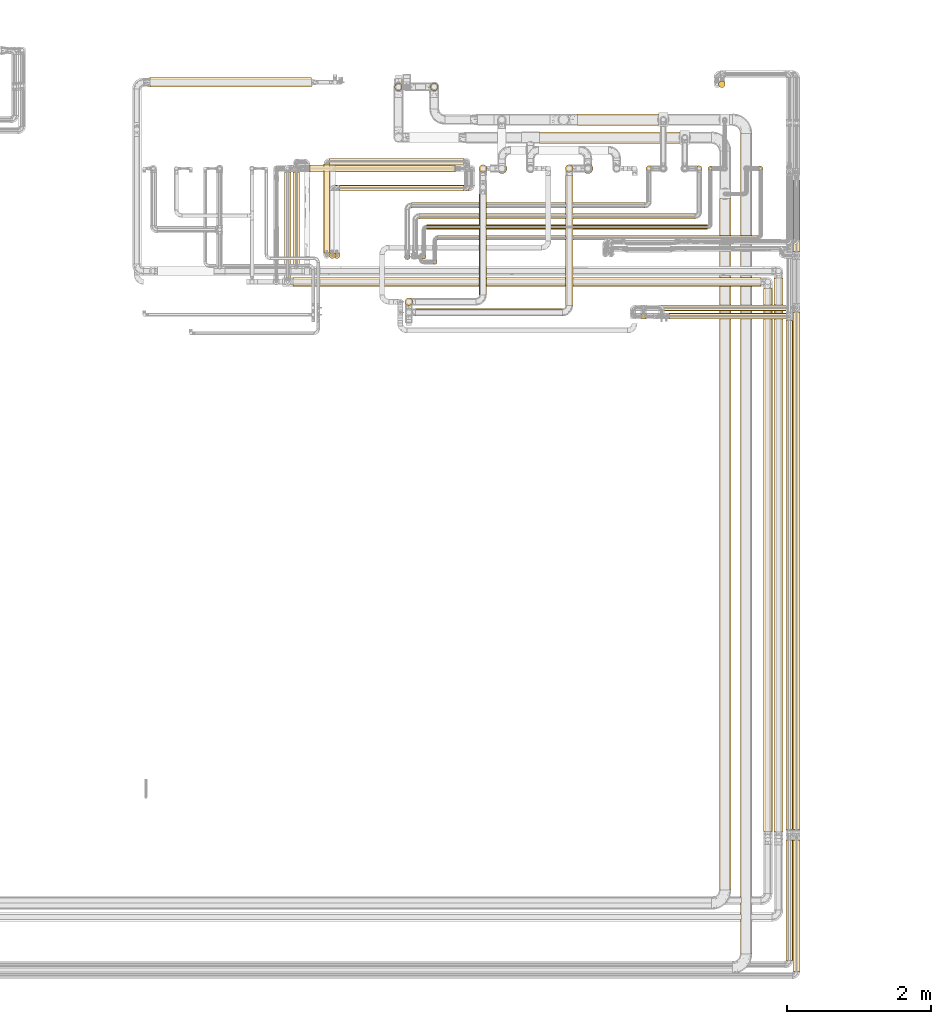
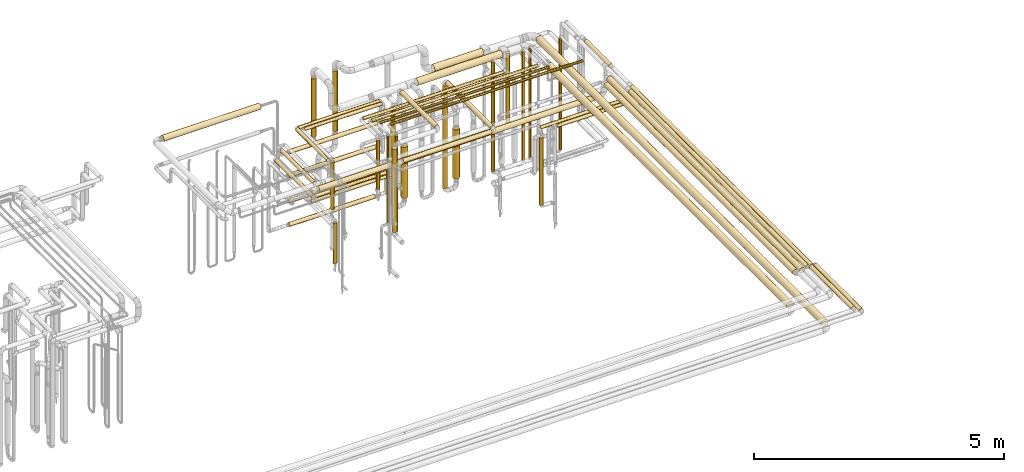
# One storey, part 8 of 827: 51 coverings.
"""IFC2X3 building model written with IfcOpenShell, lengths in millimetres."""

from ifc_helpers import new_model, entity, si_unit, converted_unit, derived_unit, direction, frame, origin, origin_2d_with_axis, place, context, subcontext, project, spatial, circle, extrude, element, save


model = new_model("IFC2X3")

# Units and contexts
model_context = context("Model", 3, precision=0.01, world=origin(), true_north=direction((6.12303176911189e-17, 1.0)))
body_context = subcontext(model_context, "Body", "Model", "MODEL_VIEW")
ifc_project = project(units=[si_unit("LENGTHUNIT", "METRE", prefix="MILLI"), si_unit("AREAUNIT", "SQUARE_METRE"), si_unit("VOLUMEUNIT", "CUBIC_METRE"), converted_unit("PLANEANGLEUNIT", "DEGREE", entity("IfcRatioMeasure", 0.0174532925199433), si_unit("PLANEANGLEUNIT", "RADIAN"), dimensions=[0, 0, 0, 0, 0, 0, 0]), si_unit("MASSUNIT", "GRAM", prefix="KILO"), derived_unit("MASSDENSITYUNIT", [(si_unit("MASSUNIT", "GRAM", prefix="KILO"), 1), (si_unit("LENGTHUNIT", "METRE"), -3)]), derived_unit("MOMENTOFINERTIAUNIT", [(si_unit("LENGTHUNIT", "METRE"), 4)]), si_unit("TIMEUNIT", "SECOND"), si_unit("FREQUENCYUNIT", "HERTZ"), si_unit("THERMODYNAMICTEMPERATUREUNIT", "DEGREE_CELSIUS"), derived_unit("THERMALTRANSMITTANCEUNIT", [(si_unit("MASSUNIT", "GRAM", prefix="KILO"), 1), (si_unit("THERMODYNAMICTEMPERATUREUNIT", "KELVIN"), -1), (si_unit("TIMEUNIT", "SECOND"), -3)]), derived_unit("VOLUMETRICFLOWRATEUNIT", [(si_unit("LENGTHUNIT", "METRE"), 3), (si_unit("TIMEUNIT", "SECOND"), -1)]), derived_unit("MASSFLOWRATEUNIT", [(si_unit("MASSUNIT", "GRAM", prefix="KILO"), 1), (si_unit("TIMEUNIT", "SECOND"), -1)]), derived_unit("ROTATIONALFREQUENCYUNIT", [(si_unit("TIMEUNIT", "SECOND"), -1)]), si_unit("ELECTRICCURRENTUNIT", "AMPERE"), si_unit("ELECTRICVOLTAGEUNIT", "VOLT"), si_unit("POWERUNIT", "WATT"), si_unit("FORCEUNIT", "NEWTON", prefix="KILO"), si_unit("ILLUMINANCEUNIT", "LUX"), si_unit("LUMINOUSFLUXUNIT", "LUMEN"), si_unit("LUMINOUSINTENSITYUNIT", "CANDELA"), derived_unit("USERDEFINED", [(si_unit("MASSUNIT", "GRAM", prefix="KILO"), -1), (si_unit("LENGTHUNIT", "METRE"), -2), (si_unit("TIMEUNIT", "SECOND"), 3), (si_unit("LUMINOUSFLUXUNIT", "LUMEN"), 1)]), derived_unit("LINEARVELOCITYUNIT", [(si_unit("LENGTHUNIT", "METRE"), 1), (si_unit("TIMEUNIT", "SECOND"), -1)]), si_unit("PRESSUREUNIT", "PASCAL"), derived_unit("USERDEFINED", [(si_unit("LENGTHUNIT", "METRE"), -2), (si_unit("MASSUNIT", "GRAM", prefix="KILO"), 1), (si_unit("TIMEUNIT", "SECOND"), -2)]), derived_unit("LINEARFORCEUNIT", [(si_unit("MASSUNIT", "GRAM", prefix="KILO"), 1), (si_unit("LENGTHUNIT", "METRE"), 1), (si_unit("TIMEUNIT", "SECOND"), -2), (si_unit("LENGTHUNIT", "METRE"), -1)]), derived_unit("PLANARFORCEUNIT", [(si_unit("MASSUNIT", "GRAM", prefix="KILO"), 1), (si_unit("LENGTHUNIT", "METRE"), 1), (si_unit("TIMEUNIT", "SECOND"), -2), (si_unit("LENGTHUNIT", "METRE"), -2)])], contexts=[model_context])

# Site, building, storey
site_placement = place(None, origin())
site = spatial("IfcSite", under=ifc_project, at=site_placement, CompositionType="ELEMENT")
building_placement = place(site_placement, origin())
building = spatial("IfcBuilding", under=site, at=building_placement, CompositionType="ELEMENT")
storey_placement = place(building_placement, frame((0.0, 0.0, 28200.0)))
storey = spatial("IfcBuildingStorey", under=building, at=storey_placement, Name="08", CompositionType="ELEMENT", Elevation=28200.0)

# Coverings
covering_1_placement = place(storey_placement, frame((60838.76, 8260.54, 2935.65)))
element("IfcCovering", 1, at=covering_1_placement, inside=storey, Name=":ADSK_", ObjectType=":ADSK_", PredefinedType="INSULATION", context=body_context, shape_type="SweptSolid", body=[
    extrude(circle(Radius=62.75, at=origin_2d_with_axis()), frame((64.35, 0.0, 64.35), z_axis=(0.0, 1.0, 0.0), x_axis=(1.0, 0.0, 0.0)), (0.0, 0.0, 1.0), 7716.83971309857),
])
covering_2_placement = place(storey_placement, frame((60075.45, 7456.2, 2816.87)))
element("IfcCovering", 2, at=covering_2_placement, inside=storey, Name=":ADSK_", ObjectType=":ADSK_", PredefinedType="INSULATION", context=body_context, shape_type="SweptSolid", body=[
    extrude(circle(Radius=81.5, at=origin_2d_with_axis()), frame((83.1, 0.0, 83.1), z_axis=(0.0, 1.0, 0.0), x_axis=(1.0, 0.0, 0.0)), (0.0, 0.0, 1.0), 9626.5836518491),
])
covering_3_placement = place(storey_placement, frame((61002.04, 8301.25, 2949.15)))
element("IfcCovering", 3, at=covering_3_placement, inside=storey, Name=":ADSK_", ObjectType=":ADSK_", PredefinedType="INSULATION", context=body_context, shape_type="SweptSolid", body=[
    extrude(circle(Radius=49.0, at=origin_2d_with_axis()), frame((50.6, 0.0, 50.6), z_axis=(0.0, 1.0, 0.0), x_axis=(1.0, 0.0, 0.0)), (0.0, 0.0, 1.0), 7085.96306405012),
])
covering_4_placement = place(storey_placement, frame((59378.46, 15400.86, 2656.65)))
element("IfcCovering", 4, at=covering_4_placement, inside=storey, Name=":ADSK_", ObjectType=":ADSK_", PredefinedType="INSULATION", context=body_context, shape_type="SweptSolid", body=[
    extrude(circle(Radius=41.75, at=origin_2d_with_axis()), frame((0.0, 43.35, 43.35), z_axis=(1.0, 0.0, 0.0), x_axis=(0.0, -1.0, 0.0)), (0.0, 0.0, 1.0), 1636.17726238864),
])
covering_5_placement = place(storey_placement, frame((61102.04, 8300.34, 2949.15)))
element("IfcCovering", 5, at=covering_5_placement, inside=storey, Name=":ADSK_", ObjectType=":ADSK_", PredefinedType="INSULATION", context=body_context, shape_type="SweptSolid", body=[
    extrude(circle(Radius=49.0, at=origin_2d_with_axis()), frame((50.6, 0.0, 50.6), z_axis=(0.0, 1.0, 0.0), x_axis=(1.0, 0.0, 0.0)), (0.0, 0.0, 1.0), 7203.18637121827),
])
covering_6_placement = place(storey_placement, frame((61102.04, 16345.88, 2949.15)))
element("IfcCovering", 6, at=covering_6_placement, inside=storey, Name=":ADSK_", ObjectType=":ADSK_", PredefinedType="INSULATION", context=body_context, shape_type="SweptSolid", body=[
    extrude(circle(Radius=49.0, at=origin_2d_with_axis()), frame((50.6, 0.0, 50.6), z_axis=(0.0, 1.0, 0.0), x_axis=(1.0, 0.0, 0.0)), (0.0, 0.0, 1.0), 994.955864647867),
])
covering_7_placement = place(storey_placement, frame((59063.14, 15517.18, 2656.65)))
element("IfcCovering", 7, at=covering_7_placement, inside=storey, Name=":ADSK_", ObjectType=":ADSK_", PredefinedType="INSULATION", context=body_context, shape_type="SweptSolid", body=[
    extrude(circle(Radius=41.75, at=origin_2d_with_axis()), frame((0.0, 43.35, 43.35), z_axis=(1.0, 0.0, 0.0), x_axis=(0.0, 1.0, 0.0)), (0.0, 0.0, 1.0), 2051.50000000003),
])
covering_8_placement = place(storey_placement, frame((58981.79, 15400.86, 908.51)))
element("IfcCovering", 8, at=covering_8_placement, inside=storey, Name=":ADSK_", ObjectType=":ADSK_", PredefinedType="INSULATION", context=body_context, shape_type="SweptSolid", body=[
    extrude(circle(Radius=41.75, at=origin_2d_with_axis()), frame((43.35, 43.35, 0.0)), (0.0, 0.0, 1.0), 1653.487023342),
])
covering_9_placement = place(storey_placement, frame((57571.89, 17847.0, 2816.87)))
element("IfcCovering", 9, at=covering_9_placement, inside=storey, Name=":ADSK_", ObjectType=":ADSK_", PredefinedType="INSULATION", context=body_context, shape_type="SweptSolid", body=[
    extrude(circle(Radius=81.5, at=origin_2d_with_axis()), frame((0.0, 83.1, 83.1), z_axis=(1.0, 0.0, 0.0), x_axis=(0.0, -1.0, 0.0)), (0.0, 0.0, 1.0), 1959.7835585026),
])
covering_10_placement = place(storey_placement, frame((55556.45, 18581.39, 1843.17)))
element("IfcCovering", 10, at=covering_10_placement, inside=storey, Name=":ADSK_", ObjectType=":ADSK_", PredefinedType="INSULATION", context=body_context, shape_type="SweptSolid", body=[
    extrude(circle(Radius=53.0, at=origin_2d_with_axis()), frame((54.6, 54.6, 0.0)), (0.0, 0.0, 1.0), 1426.57392214822),
])
covering_11_placement = place(storey_placement, frame((60065.43, 18623.72, 517.5)))
element("IfcCovering", 11, at=covering_11_placement, inside=storey, Name=":ADSK_", ObjectType=":ADSK_", PredefinedType="INSULATION", context=body_context, shape_type="SweptSolid", body=[
    extrude(circle(Radius=46.15, at=origin_2d_with_axis()), frame((47.75, 47.75, 0.0), z_axis=(0.0, 0.0, 1.0), x_axis=(0.0, -1.0, 0.0)), (0.0, 0.0, 1.0), 1769.24318880564),
])
covering_12_placement = place(storey_placement, frame((54730.19, 17456.65, 2956.65)))
element("IfcCovering", 12, at=covering_12_placement, inside=storey, Name=":ADSK_", ObjectType=":ADSK_", PredefinedType="INSULATION", context=body_context, shape_type="SweptSolid", body=[
    extrude(circle(Radius=41.75, at=origin_2d_with_axis()), frame((0.0, 43.35, 43.35), z_axis=(1.0, 0.0, 0.0), x_axis=(0.0, 1.0, 0.0)), (0.0, 0.0, 1.0), 1795.03888037783),
])
covering_13_placement = place(storey_placement, frame((54648.84, 16245.22, 1817.59)))
element("IfcCovering", 13, at=covering_13_placement, inside=storey, Name=":ADSK_", ObjectType=":ADSK_", PredefinedType="INSULATION", context=body_context, shape_type="SweptSolid", body=[
    extrude(circle(Radius=41.75, at=origin_2d_with_axis()), frame((43.35, 43.35, 0.0), z_axis=(0.0, 0.0, 1.0), x_axis=(-1.0, 0.0, 0.0)), (0.0, 0.0, 1.0), 1144.50000000002),
])
covering_14_placement = place(storey_placement, frame((54142.04, 16136.38, 2652.25)))
element("IfcCovering", 14, at=covering_14_placement, inside=storey, Name=":ADSK_", ObjectType=":ADSK_", PredefinedType="INSULATION", context=body_context, shape_type="SweptSolid", body=[
    extrude(circle(Radius=46.15, at=origin_2d_with_axis()), frame((47.75, 0.0, 47.75), z_axis=(0.0, 1.0, 0.0), x_axis=(-1.0, 0.0, 0.0)), (0.0, 0.0, 1.0), 1315.622696356),
])
covering_15_placement = place(storey_placement, frame((54378.79, 17449.4, 2516.9)))
element("IfcCovering", 15, at=covering_15_placement, inside=storey, Name=":ADSK_", ObjectType=":ADSK_", PredefinedType="INSULATION", context=body_context, shape_type="SweptSolid", body=[
    extrude(circle(Radius=49.0, at=origin_2d_with_axis()), frame((0.0, 50.6, 50.6), z_axis=(1.0, 0.0, 0.0), x_axis=(0.0, -1.0, 0.0)), (0.0, 0.0, 1.0), 2029.3993360433),
])
covering_16_placement = place(storey_placement, frame((54650.19, 17555.47, 2956.74)))
element("IfcCovering", 16, at=covering_16_placement, inside=storey, Name=":ADSK_", ObjectType=":ADSK_", PredefinedType="INSULATION", context=body_context, shape_type="SweptSolid", body=[
    extrude(circle(Radius=41.75, at=origin_2d_with_axis()), frame((0.0, 43.35, 43.35), z_axis=(1.0, 0.0, 0.0), x_axis=(0.0, 1.0, 0.0)), (0.0, 0.0, 1.0), 1875.03888037783),
])
covering_17_placement = place(storey_placement, frame((54568.84, 16326.56, 2956.65)))
element("IfcCovering", 17, at=covering_17_placement, inside=storey, Name=":ADSK_", ObjectType=":ADSK_", PredefinedType="INSULATION", context=body_context, shape_type="SweptSolid", body=[
    extrude(circle(Radius=41.75, at=origin_2d_with_axis()), frame((43.35, 0.0, 43.35), z_axis=(0.0, 1.0, 0.0), x_axis=(1.0, 0.0, 0.0)), (0.0, 0.0, 1.0), 1234.25889000002),
])
covering_18_placement = place(storey_placement, frame((54022.04, 15970.38, 2452.25)))
element("IfcCovering", 18, at=covering_18_placement, inside=storey, Name=":ADSK_", ObjectType=":ADSK_", PredefinedType="INSULATION", context=body_context, shape_type="SweptSolid", body=[
    extrude(circle(Radius=46.15, at=origin_2d_with_axis()), frame((47.75, 0.0, 47.75), z_axis=(0.0, 1.0, 0.0), x_axis=(-1.0, 0.0, 0.0)), (0.0, 0.0, 1.0), 1481.62269635603),
])
covering_19_placement = place(storey_placement, frame((54363.79, 17449.4, 1941.9)))
element("IfcCovering", 19, at=covering_19_placement, inside=storey, Name=":ADSK_", ObjectType=":ADSK_", PredefinedType="INSULATION", context=body_context, shape_type="SweptSolid", body=[
    extrude(circle(Radius=49.0, at=origin_2d_with_axis()), frame((0.0, 50.6, 50.6), z_axis=(1.0, 0.0, 0.0), x_axis=(0.0, 1.0, 0.0)), (0.0, 0.0, 1.0), 2026.89933604333),
])
covering_20_placement = place(storey_placement, frame((54730.19, 17185.22, 1356.65)))
element("IfcCovering", 20, at=covering_20_placement, inside=storey, Name=":ADSK_", ObjectType=":ADSK_", PredefinedType="INSULATION", context=body_context, shape_type="SweptSolid", body=[
    extrude(circle(Radius=41.75, at=origin_2d_with_axis()), frame((0.0, 43.35, 43.35), z_axis=(1.0, 0.0, 0.0), x_axis=(0.0, 1.0, 0.0)), (0.0, 0.0, 1.0), 1865.03888037782),
])
covering_21_placement = place(storey_placement, frame((54378.79, 17449.4, 741.9)))
element("IfcCovering", 21, at=covering_21_placement, inside=storey, Name=":ADSK_", ObjectType=":ADSK_", PredefinedType="INSULATION", context=body_context, shape_type="SweptSolid", body=[
    extrude(circle(Radius=49.0, at=origin_2d_with_axis()), frame((0.0, 50.6, 50.6), z_axis=(1.0, 0.0, 0.0), x_axis=(0.0, 1.0, 0.0)), (0.0, 0.0, 1.0), 1975.43821642111),
])
covering_22_placement = place(storey_placement, frame((54792.23, 17185.22, 1456.65)))
element("IfcCovering", 22, at=covering_22_placement, inside=storey, Name=":ADSK_", ObjectType=":ADSK_", PredefinedType="INSULATION", context=body_context, shape_type="SweptSolid", body=[
    extrude(circle(Radius=41.75, at=origin_2d_with_axis()), frame((0.0, 43.35, 43.35), z_axis=(1.0, 0.0, 0.0), x_axis=(0.0, 1.0, 0.0)), (0.0, 0.0, 1.0), 1734.00000000001),
])
covering_23_placement = place(storey_placement, frame((54710.88, 16245.22, 462.5)))
element("IfcCovering", 23, at=covering_23_placement, inside=storey, Name=":ADSK_", ObjectType=":ADSK_", PredefinedType="INSULATION", context=body_context, shape_type="SweptSolid", body=[
    extrude(circle(Radius=41.75, at=origin_2d_with_axis()), frame((43.35, 43.35, 0.0)), (0.0, 0.0, 1.0), 999.50000000002),
])
covering_24_placement = place(storey_placement, frame((54363.79, 17449.4, 1319.4)))
element("IfcCovering", 24, at=covering_24_placement, inside=storey, Name=":ADSK_", ObjectType=":ADSK_", PredefinedType="INSULATION", context=body_context, shape_type="SweptSolid", body=[
    extrude(circle(Radius=49.0, at=origin_2d_with_axis()), frame((0.0, 50.6, 50.6), z_axis=(1.0, 0.0, 0.0), x_axis=(0.0, 1.0, 0.0)), (0.0, 0.0, 1.0), 2026.43821642109),
])
covering_25_placement = place(storey_placement, frame((59757.54, 17459.4, 457.0)))
element("IfcCovering", 25, at=covering_25_placement, inside=storey, Name=":ADSK_", ObjectType=":ADSK_", PredefinedType="INSULATION", context=body_context, shape_type="SweptSolid", body=[
    extrude(circle(Radius=39.0, at=origin_2d_with_axis()), frame((40.6, 40.6, 0.0), z_axis=(0.0, 0.0, 1.0), x_axis=(-1.0, 0.0, 0.0)), (0.0, 0.0, 1.0), 2686.0),
])
covering_26_placement = place(storey_placement, frame((55900.13, 16797.34, 3159.4)))
element("IfcCovering", 26, at=covering_26_placement, inside=storey, Name=":ADSK_", ObjectType=":ADSK_", PredefinedType="INSULATION", context=body_context, shape_type="SweptSolid", body=[
    extrude(circle(Radius=39.0, at=origin_2d_with_axis()), frame((0.0, 40.6, 40.6), z_axis=(1.0, 0.0, 0.0), x_axis=(0.0, -1.0, 0.0)), (0.0, 0.0, 1.0), 3841.0),
])
covering_27_placement = place(storey_placement, frame((60619.79, 17466.65, 438.0)))
element("IfcCovering", 27, at=covering_27_placement, inside=storey, Name=":ADSK_", ObjectType=":ADSK_", PredefinedType="INSULATION", context=body_context, shape_type="SweptSolid", body=[
    extrude(circle(Radius=31.75, at=origin_2d_with_axis()), frame((33.35, 33.35, 0.0), z_axis=(0.0, 0.0, 1.0), x_axis=(-1.0, 0.0, 0.0)), (0.0, 0.0, 1.0), 2724.00000000001),
])
covering_28_placement = place(storey_placement, frame((56156.13, 16502.35, 3166.65)))
element("IfcCovering", 28, at=covering_28_placement, inside=storey, Name=":ADSK_", ObjectType=":ADSK_", PredefinedType="INSULATION", context=body_context, shape_type="SweptSolid", body=[
    extrude(circle(Radius=31.75, at=origin_2d_with_axis()), frame((0.0, 33.35, 33.35), z_axis=(1.0, 0.0, 0.0), x_axis=(0.0, -1.0, 0.0)), (0.0, 0.0, 1.0), 4459.00000000002),
])
covering_29_placement = place(storey_placement, frame((56084.79, 16164.59, 822.74)))
element("IfcCovering", 29, at=covering_29_placement, inside=storey, Name=":ADSK_", ObjectType=":ADSK_", PredefinedType="INSULATION", context=body_context, shape_type="SweptSolid", body=[
    extrude(circle(Radius=31.75, at=origin_2d_with_axis()), frame((33.35, 33.35, 0.0)), (0.0, 0.0, 1.0), 2339.25681119431),
])
covering_30_placement = place(storey_placement, frame((61102.04, 6322.71, 3049.4)))
element("IfcCovering", 30, at=covering_30_placement, inside=storey, Name=":ADSK_", ObjectType=":ADSK_", PredefinedType="INSULATION", context=body_context, shape_type="SweptSolid", body=[
    extrude(circle(Radius=49.0, at=origin_2d_with_axis()), frame((50.6, 0.0, 50.6), z_axis=(0.0, 1.0, 0.0), x_axis=(-1.0, 0.0, 0.0)), (0.0, 0.0, 1.0), 1830.15099200396),
])
covering_31_placement = place(storey_placement, frame((61002.04, 6473.57, 3049.4)))
element("IfcCovering", 31, at=covering_31_placement, inside=storey, Name=":ADSK_", ObjectType=":ADSK_", PredefinedType="INSULATION", context=body_context, shape_type="SweptSolid", body=[
    extrude(circle(Radius=49.0, at=origin_2d_with_axis()), frame((50.6, 0.0, 50.6), z_axis=(0.0, 1.0, 0.0), x_axis=(-1.0, 0.0, 0.0)), (0.0, 0.0, 1.0), 1680.20036242837),
])
covering_32_placement = place(storey_placement, frame((60367.95, 6565.0, 2816.9)))
element("IfcCovering", 32, at=covering_32_placement, inside=storey, Name=":ADSK_", ObjectType=":ADSK_", PredefinedType="INSULATION", context=body_context, shape_type="SweptSolid", body=[
    extrude(circle(Radius=81.5, at=origin_2d_with_axis()), frame((83.1, 0.0, 83.1), z_axis=(0.0, 1.0, 0.0), x_axis=(1.0, 0.0, 0.0)), (0.0, 0.0, 1.0), 11425.0955266224),
])
covering_33_placement = place(storey_placement, frame((58101.05, 18097.0, 2816.9)))
element("IfcCovering", 33, at=covering_33_placement, inside=storey, Name=":ADSK_", ObjectType=":ADSK_", PredefinedType="INSULATION", context=body_context, shape_type="SweptSolid", body=[
    extrude(circle(Radius=81.5, at=origin_2d_with_axis()), frame((0.0, 83.1, 83.1), z_axis=(1.0, 0.0, 0.0), x_axis=(0.0, -1.0, 0.0)), (0.0, 0.0, 1.0), 1131.84247335702),
])
covering_34_placement = place(storey_placement, frame((56053.95, 18581.39, 1800.0)))
element("IfcCovering", 34, at=covering_34_placement, inside=storey, Name=":ADSK_", ObjectType=":ADSK_", PredefinedType="INSULATION", context=body_context, shape_type="SweptSolid", body=[
    extrude(circle(Radius=53.0, at=origin_2d_with_axis()), frame((54.6, 54.6, 0.0), z_axis=(0.0, 0.0, 1.0), x_axis=(-1.0, 0.0, 0.0)), (0.0, 0.0, 1.0), 1469.74318880571),
])
covering_35_placement = place(storey_placement, frame((59919.79, 17466.65, 438.0)))
element("IfcCovering", 35, at=covering_35_placement, inside=storey, Name=":ADSK_", ObjectType=":ADSK_", PredefinedType="INSULATION", context=body_context, shape_type="SweptSolid", body=[
    extrude(circle(Radius=31.75, at=origin_2d_with_axis()), frame((33.35, 33.35, 0.0), z_axis=(0.0, 0.0, 1.0), x_axis=(-1.0, 0.0, 0.0)), (0.0, 0.0, 1.0), 2724.00000000001),
])
covering_36_placement = place(storey_placement, frame((59057.54, 17459.4, 457.0)))
element("IfcCovering", 36, at=covering_36_placement, inside=storey, Name=":ADSK_", ObjectType=":ADSK_", PredefinedType="INSULATION", context=body_context, shape_type="SweptSolid", body=[
    extrude(circle(Radius=39.0, at=origin_2d_with_axis()), frame((40.6, 40.6, 0.0), z_axis=(0.0, 0.0, 1.0), x_axis=(-1.0, 0.0, 0.0)), (0.0, 0.0, 1.0), 2685.99999999999),
])
covering_37_placement = place(storey_placement, frame((57933.54, 17445.65, 445.0)))
element("IfcCovering", 37, at=covering_37_placement, inside=storey, Name=":ADSK_", ObjectType=":ADSK_", PredefinedType="INSULATION", context=body_context, shape_type="SweptSolid", body=[
    extrude(circle(Radius=52.75, at=origin_2d_with_axis()), frame((54.35, 54.35, 0.0)), (0.0, 0.0, 1.0), 2509.99999999998),
])
covering_38_placement = place(storey_placement, frame((56733.04, 17445.65, 447.5)))
element("IfcCovering", 38, at=covering_38_placement, inside=storey, Name=":ADSK_", ObjectType=":ADSK_", PredefinedType="INSULATION", context=body_context, shape_type="SweptSolid", body=[
    extrude(circle(Radius=52.75, at=origin_2d_with_axis()), frame((54.35, 54.35, 0.0)), (0.0, 0.0, 1.0), 2357.49999999998),
])
covering_39_placement = place(storey_placement, frame((56003.36, 16652.35, 3166.65)))
element("IfcCovering", 39, at=covering_39_placement, inside=storey, Name=":ADSK_", ObjectType=":ADSK_", PredefinedType="INSULATION", context=body_context, shape_type="SweptSolid", body=[
    extrude(circle(Radius=31.75, at=origin_2d_with_axis()), frame((0.0, 33.35, 33.35), z_axis=(1.0, 0.0, 0.0), x_axis=(0.0, 1.0, 0.0)), (0.0, 0.0, 1.0), 3911.77267000001),
])
covering_40_placement = place(storey_placement, frame((55791.18, 16945.1, 3159.4)))
element("IfcCovering", 40, at=covering_40_placement, inside=storey, Name=":ADSK_", ObjectType=":ADSK_", PredefinedType="INSULATION", context=body_context, shape_type="SweptSolid", body=[
    extrude(circle(Radius=39.0, at=origin_2d_with_axis()), frame((0.0, 40.6, 40.6), z_axis=(1.0, 0.0, 0.0), x_axis=(0.0, -1.0, 0.0)), (0.0, 0.0, 1.0), 3249.95491),
])
covering_41_placement = place(storey_placement, frame((57933.54, 15591.2, 2995.65)))
element("IfcCovering", 41, at=covering_41_placement, inside=storey, Name=":ADSK_", ObjectType=":ADSK_", PredefinedType="INSULATION", context=body_context, shape_type="SweptSolid", body=[
    extrude(circle(Radius=52.75, at=origin_2d_with_axis()), frame((54.35, 0.0, 54.35), z_axis=(0.0, 1.0, 0.0), x_axis=(1.0, 0.0, 0.0)), (0.0, 0.0, 1.0), 1813.79588635602),
])
covering_42_placement = place(storey_placement, frame((55850.84, 15441.86, 2995.65)))
element("IfcCovering", 42, at=covering_42_placement, inside=storey, Name=":ADSK_", ObjectType=":ADSK_", PredefinedType="INSULATION", context=body_context, shape_type="SweptSolid", body=[
    extrude(circle(Radius=52.75, at=origin_2d_with_axis()), frame((0.0, 54.35, 54.35), z_axis=(1.0, 0.0, 0.0), x_axis=(0.0, -1.0, 0.0)), (0.0, 0.0, 1.0), 2042.04196819739),
])
covering_43_placement = place(storey_placement, frame((56733.04, 15741.2, 3345.65)))
element("IfcCovering", 43, at=covering_43_placement, inside=storey, Name=":ADSK_", ObjectType=":ADSK_", PredefinedType="INSULATION", context=body_context, shape_type="SweptSolid", body=[
    extrude(circle(Radius=52.75, at=origin_2d_with_axis()), frame((54.35, 0.0, 54.35), z_axis=(0.0, 1.0, 0.0), x_axis=(1.0, 0.0, 0.0)), (0.0, 0.0, 1.0), 1403.79588635601),
])
covering_44_placement = place(storey_placement, frame((55932.01, 16237.09, 1038.0)))
element("IfcCovering", 44, at=covering_44_placement, inside=storey, Name=":ADSK_", ObjectType=":ADSK_", PredefinedType="INSULATION", context=body_context, shape_type="SweptSolid", body=[
    extrude(circle(Radius=31.75, at=origin_2d_with_axis()), frame((33.35, 33.35, 0.0), z_axis=(0.0, 0.0, 1.0), x_axis=(-1.0, 0.0, 0.0)), (0.0, 0.0, 1.0), 2124.0),
])
covering_45_placement = place(storey_placement, frame((55693.58, 16227.34, 1944.16)))
element("IfcCovering", 45, at=covering_45_placement, inside=storey, Name=":ADSK_", ObjectType=":ADSK_", PredefinedType="INSULATION", context=body_context, shape_type="SweptSolid", body=[
    extrude(circle(Radius=39.0, at=origin_2d_with_axis()), frame((40.6, 40.6, 0.0), z_axis=(0.0, 0.0, 1.0), x_axis=(-1.0, 0.0, 0.0)), (0.0, 0.0, 1.0), 1198.83653388558),
])
covering_46_placement = place(storey_placement, frame((55701.5, 15591.86, 1280.0)))
element("IfcCovering", 46, at=covering_46_placement, inside=storey, Name=":ADSK_", ObjectType=":ADSK_", PredefinedType="INSULATION", context=body_context, shape_type="SweptSolid", body=[
    extrude(circle(Radius=52.75, at=origin_2d_with_axis()), frame((54.35, 54.35, 0.0), z_axis=(0.0, 0.0, 1.0), x_axis=(0.0, -1.0, 0.0)), (0.0, 0.0, 1.0), 2024.99999999996),
])
covering_47_placement = place(storey_placement, frame((58173.97, 17426.4, 602.0)))
element("IfcCovering", 47, at=covering_47_placement, inside=storey, Name=":ADSK_", ObjectType=":ADSK_", PredefinedType="INSULATION", context=body_context, shape_type="SweptSolid", body=[
    extrude(circle(Radius=72.0, at=origin_2d_with_axis()), frame((73.6, 73.6, 0.0), z_axis=(0.0, 0.0, 1.0), x_axis=(-1.0, 0.0, 0.0)), (0.0, 0.0, 1.0), 1198.45277752717),
])
covering_48_placement = place(storey_placement, frame((56976.47, 17426.4, 549.5)))
element("IfcCovering", 48, at=covering_48_placement, inside=storey, Name=":ADSK_", ObjectType=":ADSK_", PredefinedType="INSULATION", context=body_context, shape_type="SweptSolid", body=[
    extrude(circle(Radius=72.0, at=origin_2d_with_axis()), frame((73.6, 73.6, 0.0), z_axis=(0.0, 0.0, 1.0), x_axis=(-1.0, 0.0, 0.0)), (0.0, 0.0, 1.0), 1241.2431888057),
])
covering_49_placement = place(storey_placement, frame((60688.76, 8269.36, 2935.65)))
element("IfcCovering", 49, at=covering_49_placement, inside=storey, Name=":ADSK_", ObjectType=":ADSK_", PredefinedType="INSULATION", context=body_context, shape_type="SweptSolid", body=[
    extrude(circle(Radius=62.75, at=origin_2d_with_axis()), frame((64.35, 0.0, 64.35), z_axis=(0.0, 1.0, 0.0), x_axis=(1.0, 0.0, 0.0)), (0.0, 0.0, 1.0), 7558.01289309862),
])
covering_50_placement = place(storey_placement, frame((54145.79, 15858.03, 2635.65)))
element("IfcCovering", 50, at=covering_50_placement, inside=storey, Name=":ADSK_", ObjectType=":ADSK_", PredefinedType="INSULATION", context=body_context, shape_type="SweptSolid", body=[
    extrude(circle(Radius=62.75, at=origin_2d_with_axis()), frame((0.0, 64.35, 64.35), z_axis=(1.0, 0.0, 0.0), x_axis=(0.0, -1.0, 0.0)), (0.0, 0.0, 1.0), 6512.31549000001),
])
covering_51_placement = place(storey_placement, frame((52152.37, 18629.36, 2879.15)))
element("IfcCovering", 51, at=covering_51_placement, inside=storey, Name=":ADSK_", ObjectType=":ADSK_", PredefinedType="INSULATION", context=body_context, shape_type="SweptSolid", body=[
    extrude(circle(Radius=69.25, at=origin_2d_with_axis()), frame((0.0, 70.85, 70.85), z_axis=(1.0, 0.0, 0.0), x_axis=(0.0, 1.0, 0.0)), (0.0, 0.0, 1.0), 2246.69347010136),
])

save(model, "model.ifc")
